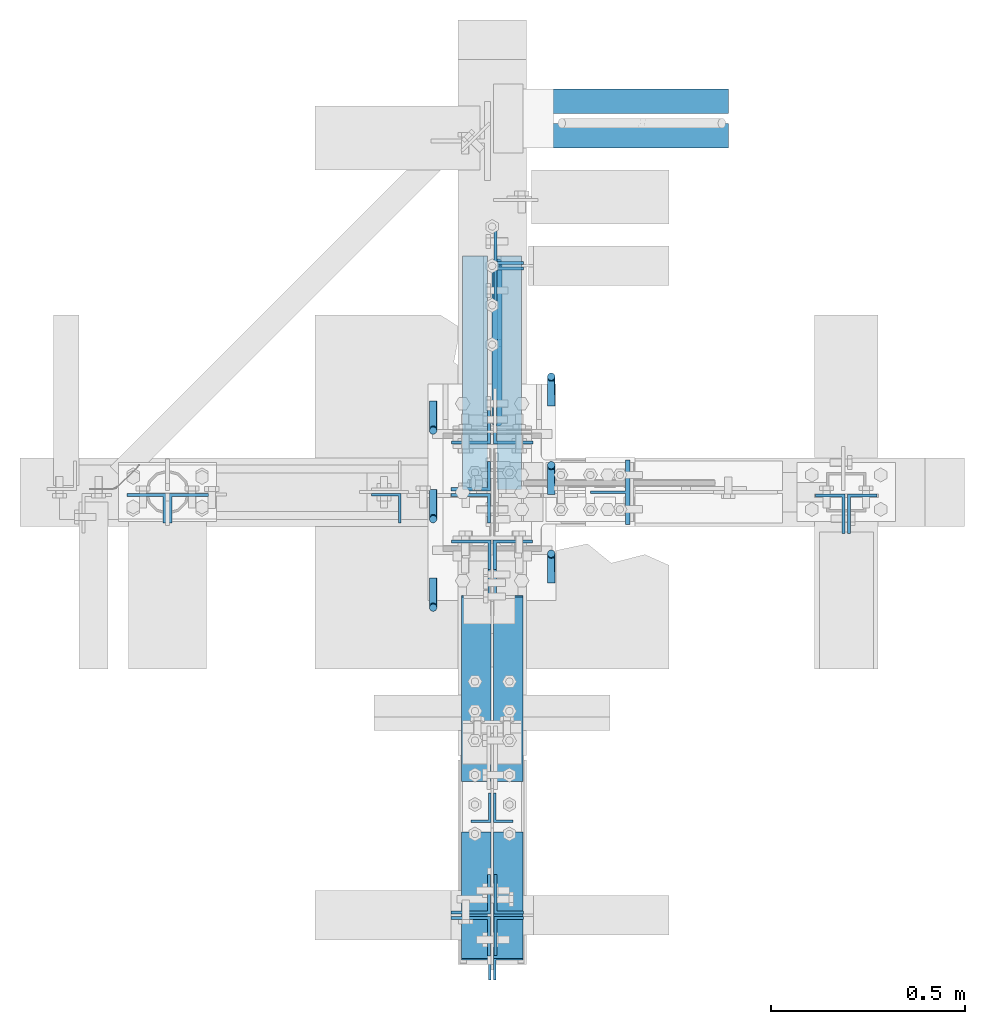
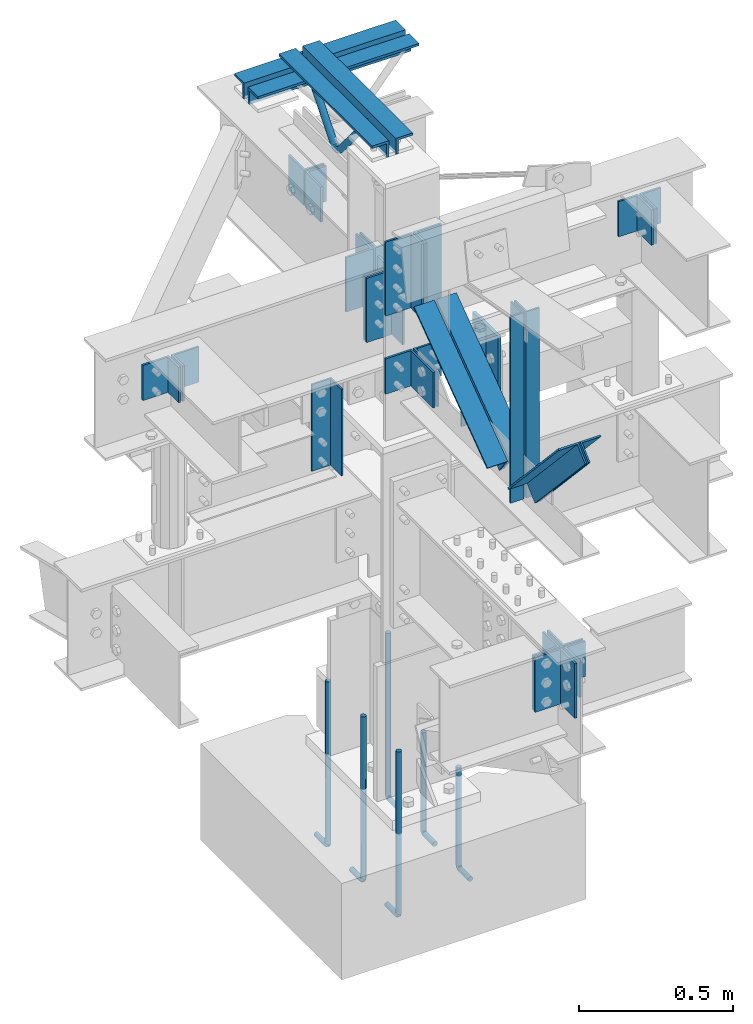
# Not in any storey, part 1 of 8: 29 members, 8 columns, 18 elements without a shape of their own.
"""IFC2X3 building model written with IfcOpenShell, lengths in inches."""

from ifc_helpers import new_model, entity, si_unit, converted_unit, frame, origin_with_axes, place, context, project, spatial, faceted_brep, source, transform, mapped, material, type_object, type_shapes, element, aggregate, save


model = new_model("IFC2X3")

# Units and contexts
model_context = context("Model", 3, precision=1e-05, world=origin_with_axes())
ifc_project = project(units=[converted_unit("LENGTHUNIT", "INCH", entity("IfcLengthMeasure", 25.4), si_unit("LENGTHUNIT", "METRE", prefix="MILLI"), dimensions=[1, 0, 0, 0, 0, 0, 0]), si_unit("PLANEANGLEUNIT", "RADIAN"), si_unit("MASSUNIT", "GRAM", prefix="KILO"), si_unit("TIMEUNIT", "SECOND"), si_unit("AREAUNIT", "SQUARE_METRE"), si_unit("PRESSUREUNIT", "PASCAL"), si_unit("FORCEUNIT", "NEWTON"), si_unit("THERMODYNAMICTEMPERATUREUNIT", "DEGREE_CELSIUS")], contexts=[model_context])

# Site, building
site_placement = place(None, origin_with_axes())
site = spatial("IfcSite", under=ifc_project, at=site_placement, CompositionType="ELEMENT")
building_placement = place(site_placement, origin_with_axes())
building = spatial("IfcBuilding", under=site, at=building_placement, Name="Building", CompositionType="ELEMENT")

# Assembly, column
assembly_1_placement = place(building_placement, frame((-9.25, 0.0, 50.0), z_axis=(-1.0, 0.0, 0.0), x_axis=(0.0, 0.0, 1.0)))
assembly_1 = element("IfcElementAssembly", 1, at=assembly_1_placement, inside=building, Name="4-5", PredefinedType="NOTDEFINED")
ifc_material_1 = material()
column_type_1 = type_object("IfcColumnType", Name="L3x3x1/4", PredefinedType="COLUMN", material=ifc_material_1)
shared_shape_1 = source(origin_with_axes(), model_context, "Body", "Brep", [
    faceted_brep([(0.0, 0.25, 0.25), (0.0, 3.0, 0.25), (0.0, 3.0, 0.0), (0.0, 0.0, 0.0), (0.0, 0.0, 3.0), (0.0, 0.25, 3.0), (13.5, 0.25, 3.0), (13.5, 0.0, 3.0), (13.5, 0.0, 0.0), (13.5, 3.0, 0.0), (13.5, 3.0, 0.25), (13.5, 0.25, 0.25)], [[[0, 1, 2, 3, 4, 5]], [[6, 7, 8, 9, 10, 11]], [[0, 11, 10, 1]], [[1, 10, 9, 2]], [[2, 9, 8, 3]], [[3, 8, 7, 4]], [[4, 7, 6, 5]], [[5, 6, 11, 0]]]),
])
type_shapes(column_type_1, [shared_shape_1])
column_1_placement = place(assembly_1_placement, frame((0.0, -0.15625, 0.0), z_axis=(0.0, -1.0, 0.0), x_axis=(1.0, 0.0, 0.0)))
column_1 = element("IfcColumn", 2, at=column_1_placement, type_object=column_type_1, Name="a36", ObjectType="Column", context=model_context, shape_type="MappedRepresentation", body=[
    mapped(shared_shape_1, transform((0.0, 0.0, 0.0), scale=1.0)),
])
aggregate(assembly_1, [column_1])

assembly_2_placement = place(building_placement, frame((14.0, 0.0, 49.0), z_axis=(0.0, -1.0, 0.0), x_axis=(0.0, 0.0, 1.0)))
assembly_2 = element("IfcElementAssembly", 3, at=assembly_2_placement, inside=building, Name="4-4", PredefinedType="NOTDEFINED")
ifc_material_2 = material()
column_type_2 = type_object("IfcColumnType", Name="WT4x14", PredefinedType="COLUMN", material=ifc_material_2)
shared_shape_2 = source(origin_with_axes(), model_context, "Body", "Brep", [
    faceted_brep([(0.0, -0.142, -4.03), (0.0, -0.142, -0.465), (0.0, -3.268, -0.465), (0.0, -3.268, 0.0), (0.0, 3.268, 0.0), (0.0, 3.268, -0.465), (0.0, 0.142, -0.465), (0.0, 0.142, -4.03), (14.625, 0.142, -4.03), (14.625, 0.142, -0.465), (14.625, 3.268, -0.465), (14.625, 3.268, 0.0), (14.625, -3.268, 0.0), (14.625, -3.268, -0.465), (14.625, -0.142, -0.465), (14.625, -0.142, -4.03)], [[[0, 1, 2, 3, 4, 5, 6, 7]], [[8, 9, 10, 11, 12, 13, 14, 15]], [[0, 15, 14, 1]], [[1, 14, 13, 2]], [[2, 13, 12, 3]], [[3, 12, 11, 4]], [[4, 11, 10, 5]], [[5, 10, 9, 6]], [[6, 9, 8, 7]], [[7, 8, 15, 0]]]),
])
type_shapes(column_type_2, [shared_shape_2])
column_2_placement = place(assembly_2_placement, frame((0.0, 0.0, 0.0), z_axis=(0.0, -1.0, 0.0), x_axis=(1.0, 0.0, 0.0)))
column_2 = element("IfcColumn", 4, at=column_2_placement, type_object=column_type_2, Name="wt6", ObjectType="Column", context=model_context, shape_type="MappedRepresentation", body=[
    mapped(shared_shape_2, transform((0.0, 0.0, 0.0), scale=1.0)),
])
aggregate(assembly_2, [column_2])

assembly_3_placement = place(building_placement, frame((3.0, 0.0, -22.6679382324219), z_axis=(0.0, -1.0, 0.0), x_axis=(0.0, 0.0, 1.0)))
assembly_3 = element("IfcElementAssembly", 5, at=assembly_3_placement, inside=building, Name="M_36", PredefinedType="NOTDEFINED")
column_3_placement = place(assembly_3_placement, frame((8.44018653035163, -3.0000000000418, 0.257887303829193), z_axis=(0.0, -1.0, 0.0), x_axis=(-1.0, 0.0, 0.0)))
cartesian_point_1 = entity("IfcCartesianPoint", [0.0, 0.0, 0.0])
ifc_direction_1 = entity("IfcDirection", [0.0, 0.0, 1.0])
ifc_direction_2 = entity("IfcDirection", [1.0, 0.0, 0.0])
column_3 = element("IfcColumn", 6, at=column_3_placement, Name="rb6", ObjectType="Member", context=model_context, shape_type="SweptSolid", body=[
    entity("IfcSurfaceCurveSweptAreaSolid", entity("IfcCircleProfileDef", "AREA", None, entity("IfcAxis2Placement2D", entity("IfcCartesianPoint", [0.0, 0.0]), entity("IfcDirection", [1.0, 0.0])), 0.375), entity("IfcAxis2Placement3D", cartesian_point_1, ifc_direction_1, ifc_direction_2), entity("IfcPolyline", [entity("IfcCartesianPoint", [0.2722, 0.0]), entity("IfcCartesianPoint", [0.2722, 2.5]), entity("IfcCartesianPoint", [0.234, 2.69304]), entity("IfcCartesianPoint", [0.0863, 2.88847]), entity("IfcCartesianPoint", [-0.164, 2.99645]), entity("IfcCartesianPoint", [-15.4778, 3.0])]), 0.0, 1.0, entity("IfcPlane", entity("IfcAxis2Placement3D", cartesian_point_1, ifc_direction_1, ifc_direction_2))),
])
aggregate(assembly_3, [column_3])

assembly_4_placement = place(building_placement, frame((3.0, -9.0, -22.6679382324219), z_axis=(0.0, -1.0, 0.0), x_axis=(0.0, 0.0, 1.0)))
assembly_4 = element("IfcElementAssembly", 7, at=assembly_4_placement, inside=building, Name="M_36", PredefinedType="NOTDEFINED")
column_4_placement = place(assembly_4_placement, frame((8.44018653035163, -3.0000000000418, 0.257887303829193), z_axis=(0.0, -1.0, 0.0), x_axis=(-1.0, 0.0, 0.0)))
cartesian_point_2 = entity("IfcCartesianPoint", [0.0, 0.0, 0.0])
ifc_direction_3 = entity("IfcDirection", [0.0, 0.0, 1.0])
ifc_direction_4 = entity("IfcDirection", [1.0, 0.0, 0.0])
column_4 = element("IfcColumn", 8, at=column_4_placement, Name="rb6", ObjectType="Member", context=model_context, shape_type="SweptSolid", body=[
    entity("IfcSurfaceCurveSweptAreaSolid", entity("IfcCircleProfileDef", "AREA", None, entity("IfcAxis2Placement2D", entity("IfcCartesianPoint", [0.0, 0.0]), entity("IfcDirection", [1.0, 0.0])), 0.375), entity("IfcAxis2Placement3D", cartesian_point_2, ifc_direction_3, ifc_direction_4), entity("IfcPolyline", [entity("IfcCartesianPoint", [0.2722, 0.0]), entity("IfcCartesianPoint", [0.2722, 2.5]), entity("IfcCartesianPoint", [0.234, 2.69304]), entity("IfcCartesianPoint", [0.0863, 2.88847]), entity("IfcCartesianPoint", [-0.164, 2.99645]), entity("IfcCartesianPoint", [-15.4778, 3.0])]), 0.0, 1.0, entity("IfcPlane", entity("IfcAxis2Placement3D", cartesian_point_2, ifc_direction_3, ifc_direction_4))),
])
aggregate(assembly_4, [column_4])

assembly_5_placement = place(building_placement, frame((3.0, 9.0, -22.6679382324219), z_axis=(0.0, -1.0, 0.0), x_axis=(0.0, 0.0, 1.0)))
assembly_5 = element("IfcElementAssembly", 9, at=assembly_5_placement, inside=building, Name="M_48", PredefinedType="NOTDEFINED")
column_5_placement = place(assembly_5_placement, frame((8.44018653035163, -3.0000000000418, 0.257887303829193), z_axis=(0.0, -1.0, 0.0), x_axis=(-1.0, 0.0, 0.0)))
cartesian_point_3 = entity("IfcCartesianPoint", [0.0, 0.0, 0.0])
ifc_direction_5 = entity("IfcDirection", [0.0, 0.0, 1.0])
ifc_direction_6 = entity("IfcDirection", [1.0, 0.0, 0.0])
column_5 = element("IfcColumn", 10, at=column_5_placement, Name="rb8", ObjectType="Member", context=model_context, shape_type="SweptSolid", body=[
    entity("IfcSurfaceCurveSweptAreaSolid", entity("IfcCircleProfileDef", "AREA", None, entity("IfcAxis2Placement2D", entity("IfcCartesianPoint", [0.0, 0.0]), entity("IfcDirection", [1.0, 0.0])), 0.375), entity("IfcAxis2Placement3D", cartesian_point_3, ifc_direction_5, ifc_direction_6), entity("IfcPolyline", [entity("IfcCartesianPoint", [0.2722, 0.0]), entity("IfcCartesianPoint", [0.2722, 2.5]), entity("IfcCartesianPoint", [0.234, 2.69304]), entity("IfcCartesianPoint", [0.0863, 2.88847]), entity("IfcCartesianPoint", [-0.164, 2.99645]), entity("IfcCartesianPoint", [-25.4778, 3.0])]), 0.0, 1.0, entity("IfcPlane", entity("IfcAxis2Placement3D", cartesian_point_3, ifc_direction_5, ifc_direction_6))),
])
aggregate(assembly_5, [column_5])

assembly_6_placement = place(building_placement, frame((-3.0, 0.0, -22.6679382324219), z_axis=(0.0, -1.0, 0.0), x_axis=(0.0, 0.0, 1.0)))
assembly_6 = element("IfcElementAssembly", 11, at=assembly_6_placement, inside=building, Name="M_35", PredefinedType="NOTDEFINED")
column_6_placement = place(assembly_6_placement, frame((8.44018653035163, 3.0000000000418, -0.257887303829193), z_axis=(0.0, 1.0, 0.0), x_axis=(-1.0, 0.0, 0.0)))
cartesian_point_4 = entity("IfcCartesianPoint", [0.0, 0.0, 0.0])
ifc_direction_7 = entity("IfcDirection", [0.0, 0.0, 1.0])
ifc_direction_8 = entity("IfcDirection", [1.0, 0.0, 0.0])
column_6 = element("IfcColumn", 12, at=column_6_placement, Name="rb6", ObjectType="Member", context=model_context, shape_type="SweptSolid", body=[
    entity("IfcSurfaceCurveSweptAreaSolid", entity("IfcCircleProfileDef", "AREA", None, entity("IfcAxis2Placement2D", entity("IfcCartesianPoint", [0.0, 0.0]), entity("IfcDirection", [1.0, 0.0])), 0.375), entity("IfcAxis2Placement3D", cartesian_point_4, ifc_direction_7, ifc_direction_8), entity("IfcPolyline", [entity("IfcCartesianPoint", [0.2722, 0.0]), entity("IfcCartesianPoint", [0.2722, 2.5]), entity("IfcCartesianPoint", [0.234, 2.69304]), entity("IfcCartesianPoint", [0.0863, 2.88847]), entity("IfcCartesianPoint", [-0.164, 2.99645]), entity("IfcCartesianPoint", [-25.4778, 3.0])]), 0.0, 1.0, entity("IfcPlane", entity("IfcAxis2Placement3D", cartesian_point_4, ifc_direction_7, ifc_direction_8))),
])
aggregate(assembly_6, [column_6])

assembly_7_placement = place(building_placement, frame((-3.0, -9.0, -22.6679382324219), z_axis=(0.0, -1.0, 0.0), x_axis=(0.0, 0.0, 1.0)))
assembly_7 = element("IfcElementAssembly", 13, at=assembly_7_placement, inside=building, Name="M_35", PredefinedType="NOTDEFINED")
column_7_placement = place(assembly_7_placement, frame((8.44018653035163, 3.0000000000418, -0.257887303829193), z_axis=(0.0, 1.0, 0.0), x_axis=(-1.0, 0.0, 0.0)))
cartesian_point_5 = entity("IfcCartesianPoint", [0.0, 0.0, 0.0])
ifc_direction_9 = entity("IfcDirection", [0.0, 0.0, 1.0])
ifc_direction_10 = entity("IfcDirection", [1.0, 0.0, 0.0])
column_7 = element("IfcColumn", 14, at=column_7_placement, Name="rb6", ObjectType="Member", context=model_context, shape_type="SweptSolid", body=[
    entity("IfcSurfaceCurveSweptAreaSolid", entity("IfcCircleProfileDef", "AREA", None, entity("IfcAxis2Placement2D", entity("IfcCartesianPoint", [0.0, 0.0]), entity("IfcDirection", [1.0, 0.0])), 0.375), entity("IfcAxis2Placement3D", cartesian_point_5, ifc_direction_9, ifc_direction_10), entity("IfcPolyline", [entity("IfcCartesianPoint", [0.2722, 0.0]), entity("IfcCartesianPoint", [0.2722, 2.5]), entity("IfcCartesianPoint", [0.234, 2.69304]), entity("IfcCartesianPoint", [0.0863, 2.88847]), entity("IfcCartesianPoint", [-0.164, 2.99645]), entity("IfcCartesianPoint", [-25.4778, 3.0])]), 0.0, 1.0, entity("IfcPlane", entity("IfcAxis2Placement3D", cartesian_point_5, ifc_direction_9, ifc_direction_10))),
])
aggregate(assembly_7, [column_7])

assembly_8_placement = place(building_placement, frame((-3.0, 9.0, -22.6679382324219), z_axis=(0.0, -1.0, 0.0), x_axis=(0.0, 0.0, 1.0)))
assembly_8 = element("IfcElementAssembly", 15, at=assembly_8_placement, inside=building, Name="M_50", PredefinedType="NOTDEFINED")
column_8_placement = place(assembly_8_placement, frame((8.44018653035163, 3.0000000000418, -0.257887303829193), z_axis=(0.0, 1.0, 0.0), x_axis=(-1.0, 0.0, 0.0)))
cartesian_point_6 = entity("IfcCartesianPoint", [0.0, 0.0, 0.0])
ifc_direction_11 = entity("IfcDirection", [0.0, 0.0, 1.0])
ifc_direction_12 = entity("IfcDirection", [1.0, 0.0, 0.0])
column_8 = element("IfcColumn", 16, at=column_8_placement, Name="rb8", ObjectType="Member", context=model_context, shape_type="SweptSolid", body=[
    entity("IfcSurfaceCurveSweptAreaSolid", entity("IfcCircleProfileDef", "AREA", None, entity("IfcAxis2Placement2D", entity("IfcCartesianPoint", [0.0, 0.0]), entity("IfcDirection", [1.0, 0.0])), 0.375), entity("IfcAxis2Placement3D", cartesian_point_6, ifc_direction_11, ifc_direction_12), entity("IfcPolyline", [entity("IfcCartesianPoint", [0.2722, 0.0]), entity("IfcCartesianPoint", [0.2722, 2.5]), entity("IfcCartesianPoint", [0.234, 2.69304]), entity("IfcCartesianPoint", [0.0863, 2.88847]), entity("IfcCartesianPoint", [-0.164, 2.99645]), entity("IfcCartesianPoint", [-25.4778, 3.0])]), 0.0, 1.0, entity("IfcPlane", entity("IfcAxis2Placement3D", cartesian_point_6, ifc_direction_11, ifc_direction_12))),
])
aggregate(assembly_8, [column_8])

# Assembly, member
assembly_9_placement = place(building_placement, frame((0.0, 0.0, 97.0), z_axis=(0.0, 0.0, -1.0), x_axis=(0.0, 1.0, 0.0)))
assembly_9 = element("IfcElementAssembly", 17, at=assembly_9_placement, inside=building, Name="M_40", PredefinedType="NOTDEFINED")
member_type_1 = type_object("IfcMemberType", Name="L2-1/2x2-1/2x3/8", PredefinedType="USERDEFINED", material=ifc_material_1)
shared_shape_3 = source(origin_with_axes(), model_context, "Body", "Brep", [
    faceted_brep([(0.0, 0.375, 0.375), (0.0, 2.5, 0.375), (0.0, 2.5, 0.0), (0.0, 0.0, 0.0), (0.0, 0.0, 2.5), (0.0, 0.375, 2.5), (23.75, 0.375, 2.5), (23.75, 0.0, 2.5), (23.75, 0.0, 0.0), (23.75, 2.5, 0.0), (23.75, 2.5, 0.375), (23.75, 0.375, 0.375)], [[[0, 1, 2, 3, 4, 5]], [[6, 7, 8, 9, 10, 11]], [[0, 11, 10, 1]], [[1, 10, 9, 2]], [[2, 9, 8, 3]], [[3, 8, 7, 4]], [[4, 7, 6, 5]], [[5, 6, 11, 0]]]),
])
type_shapes(member_type_1, [shared_shape_3])
member_1_placement = place(assembly_9_placement, frame((0.25, 0.5, 0.0), z_axis=(0.0, 0.0, 1.0), x_axis=(1.0, 0.0, 0.0)))
member_1 = element("IfcMember", 18, at=member_1_placement, type_object=member_type_1, Name="a32", ObjectType="Member", context=model_context, shape_type="MappedRepresentation", body=[
    mapped(shared_shape_3, transform((0.0, 0.0, 0.0), scale=1.0)),
])

assembly_10_placement = place(building_placement, frame((0.0, 38.0, 82.5), z_axis=(0.0, 0.0, -1.0), x_axis=(1.0, 0.0, 0.0)))
assembly_10 = element("IfcElementAssembly", 19, at=assembly_10_placement, inside=building, Name="M_41", PredefinedType="NOTDEFINED")
member_2_placement = place(assembly_10_placement, frame((0.25, 0.5, 0.0), z_axis=(0.0, 0.0, 1.0), x_axis=(1.0, 0.0, 0.0)))
member_2 = element("IfcMember", 20, at=member_2_placement, type_object=member_type_1, Name="a32", ObjectType="Member", context=model_context, shape_type="MappedRepresentation", body=[
    mapped(shared_shape_3, transform((0.0, 0.0, 0.0), scale=1.0)),
])

# Member
member_type_2 = type_object("IfcMemberType", Name="L2-1/2x2-1/2x3/8", PredefinedType="USERDEFINED", material=ifc_material_1)
shared_shape_4 = source(origin_with_axes(), model_context, "Body", "Brep", [
    faceted_brep([(0.0, 0.0, 0.0), (0.0, -2.5, 0.0), (0.0, -2.5, 0.375), (0.0, -0.375, 0.375), (0.0, -0.375, 2.5), (0.0, 0.0, 2.5), (23.75, 0.0, 2.5), (23.75, -0.375, 2.5), (23.75, -0.375, 0.375), (23.75, -2.5, 0.375), (23.75, -2.5, 0.0), (23.75, 0.0, 0.0)], [[[0, 1, 2, 3, 4, 5]], [[6, 7, 8, 9, 10, 11]], [[0, 11, 10, 1]], [[1, 10, 9, 2]], [[2, 9, 8, 3]], [[3, 8, 7, 4]], [[4, 7, 6, 5]], [[5, 6, 11, 0]]]),
])
type_shapes(member_type_2, [shared_shape_4])
member_3_placement = place(assembly_9_placement, frame((0.25, -0.5, 0.0), z_axis=(0.0, 0.0, 1.0), x_axis=(1.0, 0.0, 0.0)))
member_3 = element("IfcMember", 21, at=member_3_placement, type_object=member_type_2, Name="a6", ObjectType="Member", context=model_context, shape_type="MappedRepresentation", body=[
    mapped(shared_shape_4, transform((0.0, 0.0, 0.0), scale=1.0)),
])

member_4_placement = place(assembly_10_placement, frame((0.25, -0.5, 0.0), z_axis=(0.0, 0.0, 1.0), x_axis=(1.0, 0.0, 0.0)))
member_4 = element("IfcMember", 22, at=member_4_placement, type_object=member_type_2, Name="a6", ObjectType="Member", context=model_context, shape_type="MappedRepresentation", body=[
    mapped(shared_shape_4, transform((0.0, 0.0, 0.0), scale=1.0)),
])

aggregate(assembly_10, [member_4, member_2])

# Assembly, members
assembly_11_placement = place(building_placement, frame((0.0, -43.0, 46.0), z_axis=(0.0, 0.0, 1.0), x_axis=(1.0, 0.0, 0.0)))
assembly_11 = element("IfcElementAssembly", 23, at=assembly_11_placement, inside=building, Name="3-6", PredefinedType="NOTDEFINED")
member_type_3 = type_object("IfcMemberType", Name="L4x3x5/16", PredefinedType="USERDEFINED", material=ifc_material_1)
shared_shape_5 = source(origin_with_axes(), model_context, "Body", "Brep", [
    faceted_brep([(0.0, 0.0, 0.0), (0.0, -3.0, 0.0), (0.0, -3.0, 0.3125), (0.0, -0.3125, 0.3125), (0.0, -0.3125, 4.0), (0.0, 0.0, 4.0), (5.5, 0.0, 4.0), (5.5, -0.3125, 4.0), (5.5, -0.3125, 0.3125), (5.5, -3.0, 0.3125), (5.5, -3.0, 0.0), (5.5, 0.0, 0.0)], [[[0, 1, 2, 3, 4, 5]], [[6, 7, 8, 9, 10, 11]], [[0, 11, 10, 1]], [[1, 10, 9, 2]], [[2, 9, 8, 3]], [[3, 8, 7, 4]], [[4, 7, 6, 5]], [[5, 6, 11, 0]]]),
])
type_shapes(member_type_3, [shared_shape_5])
member_5_placement = place(assembly_11_placement, frame((0.1875, -0.117499999701977, -7.25), z_axis=(0.0, -1.0, 0.0), x_axis=(0.0, 0.0, 1.0)))
member_5 = element("IfcMember", 24, at=member_5_placement, type_object=member_type_3, Name="a12", ObjectType="Beam", context=model_context, shape_type="MappedRepresentation", body=[
    mapped(shared_shape_5, transform((0.0, 0.0, 0.0), scale=1.0)),
])
member_6_placement = place(assembly_11_placement, frame((0.1875, 0.117499999701977, -1.75), z_axis=(0.0, 1.0, 0.0), x_axis=(0.0, 0.0, -1.0)))
member_6 = element("IfcMember", 25, at=member_6_placement, type_object=member_type_3, Name="a12", ObjectType="Beam", context=model_context, shape_type="MappedRepresentation", body=[
    mapped(shared_shape_5, transform((0.0, 0.0, 0.0), scale=1.0)),
])
aggregate(assembly_11, [member_5, member_6])

assembly_12_placement = place(building_placement, frame((-33.0, 0.0, 77.0), z_axis=(0.0, 0.0, 1.0), x_axis=(0.0, -1.0, 0.0)))
assembly_12 = element("IfcElementAssembly", 26, at=assembly_12_placement, inside=building, Name="3-10", PredefinedType="NOTDEFINED")
member_7_placement = place(assembly_12_placement, frame((0.125, -0.144999995827675, -7.25), z_axis=(0.0, -1.0, 0.0), x_axis=(0.0, 0.0, 1.0)))
member_7 = element("IfcMember", 27, at=member_7_placement, type_object=member_type_3, Name="a31", ObjectType="Beam", context=model_context, shape_type="MappedRepresentation", body=[
    mapped(shared_shape_5, transform((0.0, 0.0, 0.0), scale=1.0)),
])
member_8_placement = place(assembly_12_placement, frame((0.125, 0.144999995827675, -1.75), z_axis=(0.0, 1.0, 0.0), x_axis=(0.0, 0.0, -1.0)))
member_8 = element("IfcMember", 28, at=member_8_placement, type_object=member_type_3, Name="a31", ObjectType="Beam", context=model_context, shape_type="MappedRepresentation", body=[
    mapped(shared_shape_5, transform((0.0, 0.0, 0.0), scale=1.0)),
])
aggregate(assembly_12, [member_7, member_8])

assembly_13_placement = place(building_placement, frame((0.0, 23.0, 82.5), z_axis=(0.0, 0.0, 1.0), x_axis=(1.0, 0.0, 0.0)))
assembly_13 = element("IfcElementAssembly", 29, at=assembly_13_placement, inside=building, Name="3-11", PredefinedType="NOTDEFINED")
member_9_placement = place(assembly_13_placement, frame((0.1875, -0.125, -9.75), z_axis=(0.0, -1.0, 0.0), x_axis=(0.0, 0.0, 1.0)))
member_9 = element("IfcMember", 30, at=member_9_placement, type_object=member_type_3, Name="a31", ObjectType="Beam", context=model_context, shape_type="MappedRepresentation", body=[
    mapped(shared_shape_5, transform((0.0, 0.0, 0.0), scale=1.0)),
])
member_10_placement = place(assembly_13_placement, frame((0.1875, 0.125, -4.25), z_axis=(0.0, 1.0, 0.0), x_axis=(0.0, 0.0, -1.0)))
member_10 = element("IfcMember", 31, at=member_10_placement, type_object=member_type_3, Name="a31", ObjectType="Beam", context=model_context, shape_type="MappedRepresentation", body=[
    mapped(shared_shape_5, transform((0.0, 0.0, 0.0), scale=1.0)),
])
aggregate(assembly_13, [member_9, member_10])

assembly_14_placement = place(building_placement, frame((0.0, -43.0, 46.0), z_axis=(0.0, 0.0, 1.0), x_axis=(-1.0, 0.0, 0.0)))
assembly_14 = element("IfcElementAssembly", 32, at=assembly_14_placement, inside=building, Name="3-5", PredefinedType="NOTDEFINED")
member_type_4 = type_object("IfcMemberType", Name="L4x4x5/16", PredefinedType="USERDEFINED", material=ifc_material_1)
shared_shape_6 = source(origin_with_axes(), model_context, "Body", "Brep", [
    faceted_brep([(0.0, 0.0, 0.0), (0.0, -4.0, 0.0), (0.0, -4.0, 0.3125), (0.0, -0.3125, 0.3125), (0.0, -0.3125, 4.0), (0.0, 0.0, 4.0), (8.5, 0.0, 4.0), (8.5, -0.3125, 4.0), (8.5, -0.3125, 0.3125), (8.5, -4.0, 0.3125), (8.5, -4.0, 0.0), (8.5, 0.0, 0.0)], [[[0, 1, 2, 3, 4, 5]], [[6, 7, 8, 9, 10, 11]], [[0, 11, 10, 1]], [[1, 10, 9, 2]], [[2, 9, 8, 3]], [[3, 8, 7, 4]], [[4, 7, 6, 5]], [[5, 6, 11, 0]]]),
])
type_shapes(member_type_4, [shared_shape_6])
member_11_placement = place(assembly_14_placement, frame((0.1875, -0.127499997615814, -10.25), z_axis=(0.0, -1.0, 0.0), x_axis=(0.0, 0.0, 1.0)))
member_11 = element("IfcMember", 33, at=member_11_placement, type_object=member_type_4, Name="a9", ObjectType="Beam", context=model_context, shape_type="MappedRepresentation", body=[
    mapped(shared_shape_6, transform((0.0, 0.0, 0.0), scale=1.0)),
])
member_12_placement = place(assembly_14_placement, frame((0.1875, 0.127499997615814, -1.75), z_axis=(0.0, 1.0, 0.0), x_axis=(0.0, 0.0, -1.0)))
member_12 = element("IfcMember", 34, at=member_12_placement, type_object=member_type_4, Name="a9", ObjectType="Beam", context=model_context, shape_type="MappedRepresentation", body=[
    mapped(shared_shape_6, transform((0.0, 0.0, 0.0), scale=1.0)),
])
aggregate(assembly_14, [member_11, member_12])

assembly_15_placement = place(building_placement, frame((0.0, 0.0, 80.0), z_axis=(0.0, 0.0, 1.0), x_axis=(0.0, 1.0, 0.0)))
assembly_15 = element("IfcElementAssembly", 35, at=assembly_15_placement, inside=building, Name="2-6", PredefinedType="NOTDEFINED")
member_13_placement = place(assembly_15_placement, frame((4.875, -0.14750000834465, -11.25), z_axis=(0.0, -1.0, 0.0), x_axis=(0.0, 0.0, 1.0)))
member_13 = element("IfcMember", 36, at=member_13_placement, type_object=member_type_4, Name="a7", ObjectType="Beam", context=model_context, shape_type="MappedRepresentation", body=[
    mapped(shared_shape_6, transform((0.0, 0.0, 0.0), scale=1.0)),
])
member_14_placement = place(assembly_15_placement, frame((4.875, 0.14750000834465, -2.75), z_axis=(0.0, 1.0, 0.0), x_axis=(0.0, 0.0, -1.0)))
member_14 = element("IfcMember", 37, at=member_14_placement, type_object=member_type_4, Name="a7", ObjectType="Beam", context=model_context, shape_type="MappedRepresentation", body=[
    mapped(shared_shape_6, transform((0.0, 0.0, 0.0), scale=1.0)),
])
aggregate(assembly_15, [member_13, member_14])

assembly_16_placement = place(building_placement, frame((0.0, 0.0, 80.0), z_axis=(0.0, 0.0, 1.0), x_axis=(-1.0, 0.0, 0.0)))
assembly_16 = element("IfcElementAssembly", 38, at=assembly_16_placement, inside=building, Name="2-7", PredefinedType="NOTDEFINED")
member_type_5 = type_object("IfcMemberType", Name="L4x3x5/16", PredefinedType="USERDEFINED", material=ifc_material_1)
shared_shape_7 = source(origin_with_axes(), model_context, "Body", "Brep", [
    faceted_brep([(0.0, 0.3125, 0.3125), (0.0, 3.0, 0.3125), (0.0, 3.0, 0.0), (0.0, 0.0, 0.0), (0.0, 0.0, 4.0), (0.0, 0.3125, 4.0), (10.0, 0.3125, 4.0), (10.0, 0.0, 4.0), (10.0, 0.0, 0.0), (10.0, 3.0, 0.0), (10.0, 3.0, 0.3125), (10.0, 0.3125, 0.3125)], [[[0, 1, 2, 3, 4, 5]], [[6, 7, 8, 9, 10, 11]], [[0, 11, 10, 1]], [[1, 10, 9, 2]], [[2, 9, 8, 3]], [[3, 8, 7, 4]], [[4, 7, 6, 5]], [[5, 6, 11, 0]]]),
])
type_shapes(member_type_5, [shared_shape_7])
member_15_placement = place(assembly_16_placement, frame((0.1875, -0.137500002980232, -12.75), z_axis=(1.0, 0.0, 0.0), x_axis=(0.0, 0.0, 1.0)))
member_15 = element("IfcMember", 39, at=member_15_placement, type_object=member_type_5, Name="a8", ObjectType="Beam", context=model_context, shape_type="MappedRepresentation", body=[
    mapped(shared_shape_7, transform((0.0, 0.0, 0.0), scale=1.0)),
])
member_16_placement = place(assembly_16_placement, frame((0.1875, 0.137500002980232, -2.75), z_axis=(1.0, 0.0, 0.0), x_axis=(0.0, 0.0, -1.0)))
member_16 = element("IfcMember", 40, at=member_16_placement, type_object=member_type_5, Name="a10", ObjectType="Beam", context=model_context, shape_type="MappedRepresentation", body=[
    mapped(shared_shape_7, transform((0.0, 0.0, 0.0), scale=1.0)),
])
aggregate(assembly_16, [member_15, member_16])

assembly_17_placement = place(building_placement, frame((36.0, 0.0, 78.0), z_axis=(0.0, 0.0, 1.0), x_axis=(0.0, -1.0, 0.0)))
assembly_17 = element("IfcElementAssembly", 41, at=assembly_17_placement, inside=building, Name="3-9", PredefinedType="NOTDEFINED")
member_type_6 = type_object("IfcMemberType", Name="L4x3x5/16", PredefinedType="USERDEFINED", material=ifc_material_1)
shared_shape_8 = source(origin_with_axes(), model_context, "Body", "Brep", [
    faceted_brep([(0.0, 0.3125, 0.3125), (0.0, 3.0, 0.3125), (0.0, 3.0, 0.0), (0.0, 0.0, 0.0), (0.0, 0.0, 4.0), (0.0, 0.3125, 4.0), (5.5, 0.3125, 4.0), (5.5, 0.0, 4.0), (5.5, 0.0, 0.0), (5.5, 3.0, 0.0), (5.5, 3.0, 0.3125), (5.5, 0.3125, 0.3125)], [[[0, 1, 2, 3, 4, 5]], [[6, 7, 8, 9, 10, 11]], [[0, 11, 10, 1]], [[1, 10, 9, 2]], [[2, 9, 8, 3]], [[3, 8, 7, 4]], [[4, 7, 6, 5]], [[5, 6, 11, 0]]]),
])
type_shapes(member_type_6, [shared_shape_8])
member_17_placement = place(assembly_17_placement, frame((0.1875, -0.115000002086163, -7.25), z_axis=(1.0, 0.0, 0.0), x_axis=(0.0, 0.0, 1.0)))
member_17 = element("IfcMember", 42, at=member_17_placement, type_object=member_type_6, Name="a5", ObjectType="Beam", context=model_context, shape_type="MappedRepresentation", body=[
    mapped(shared_shape_8, transform((0.0, 0.0, 0.0), scale=1.0)),
])
member_18_placement = place(assembly_17_placement, frame((0.1875, 0.115000002086163, -1.75), z_axis=(1.0, 0.0, 0.0), x_axis=(0.0, 0.0, -1.0)))
member_18 = element("IfcMember", 43, at=member_18_placement, type_object=member_type_6, Name="a5", ObjectType="Beam", context=model_context, shape_type="MappedRepresentation", body=[
    mapped(shared_shape_8, transform((0.0, 0.0, 0.0), scale=1.0)),
])
aggregate(assembly_17, [member_17, member_18])

assembly_18_placement = place(building_placement, frame((0.0, -47.9999999999999, 94.0), z_axis=(0.0, 0.17437043319647, 0.984680126755321), x_axis=(0.0, 0.98468012675532, -0.17437043319647)))
assembly_18 = element("IfcElementAssembly", 44, at=assembly_18_placement, inside=building, Name="4-8", PredefinedType="NOTDEFINED")
member_type_7 = type_object("IfcMemberType", Name="L4x3x5/16", PredefinedType="USERDEFINED", material=ifc_material_1)
shared_shape_9 = source(origin_with_axes(), model_context, "Body", "Brep", [
    faceted_brep([(0.0, 0.3125, 0.3125), (0.0, 3.0, 0.3125), (0.0, 3.0, 0.0), (0.0, 0.0, 0.0), (0.0, 0.0, 4.0), (0.0, 0.3125, 4.0), (11.5, 0.3125, 4.0), (11.5, 0.0, 4.0), (11.5, 0.0, 0.0), (11.5, 3.0, 0.0), (11.5, 3.0, 0.3125), (11.5, 0.3125, 0.3125)], [[[0, 1, 2, 3, 4, 5]], [[6, 7, 8, 9, 10, 11]], [[0, 11, 10, 1]], [[1, 10, 9, 2]], [[2, 9, 8, 3]], [[3, 8, 7, 4]], [[4, 7, 6, 5]], [[5, 6, 11, 0]]]),
])
type_shapes(member_type_7, [shared_shape_9])
member_19_placement = place(assembly_18_placement, frame((45.9081465219534, -0.107503354549408, -11.9277075718198), z_axis=(0.0, -1.0, 0.0), x_axis=(-0.17437043319647, 0.0, 0.984680126755321)))
member_19 = element("IfcMember", 45, at=member_19_placement, type_object=member_type_7, Name="a16", ObjectType="Beam", context=model_context, shape_type="MappedRepresentation", body=[
    mapped(shared_shape_9, transform((0.0, 0.0, 0.0), scale=1.0)),
])
member_20_placement = place(assembly_18_placement, frame((43.9028865401939, 0.122502744197844, -0.603886114133672), z_axis=(0.0, 1.0, 0.0), x_axis=(0.17437043319647, 0.0, -0.984680126755321)))
member_20 = element("IfcMember", 46, at=member_20_placement, type_object=member_type_7, Name="a16", ObjectType="Beam", context=model_context, shape_type="MappedRepresentation", body=[
    mapped(shared_shape_9, transform((0.0, 0.0, 0.0), scale=1.0)),
])
member_type_8 = type_object("IfcMemberType", Name="L6x4x5/16", PredefinedType="USERDEFINED", material=ifc_material_1)
shared_shape_10 = source(origin_with_axes(), model_context, "Body", "Brep", [
    faceted_brep([(0.0, 0.3125, 0.3125), (0.0, 4.0, 0.3125), (0.0, 4.0, 0.0), (0.0, 0.0, 0.0), (0.0, 0.0, 6.0), (0.0, 0.3125, 6.0), (5.5, 0.3125, 6.0), (5.5, 0.0, 6.0), (5.5, 0.0, 0.0), (5.5, 4.0, 0.0), (5.5, 4.0, 0.3125), (5.5, 0.3125, 0.3125)], [[[0, 1, 2, 3, 4, 5]], [[6, 7, 8, 9, 10, 11]], [[0, 11, 10, 1]], [[1, 10, 9, 2]], [[2, 9, 8, 3]], [[3, 8, 7, 4]], [[4, 7, 6, 5]], [[5, 6, 11, 0]]]),
])
type_shapes(member_type_8, [shared_shape_10])
member_21_placement = place(assembly_18_placement, frame((48.0431350813066, 0.115000002086163, -23.9267525398229), z_axis=(-0.98468012675532, 0.0, -0.17437043319647), x_axis=(-0.17437043319647, 0.0, 0.984680126755321)))
member_21 = element("IfcMember", 47, at=member_21_placement, type_object=member_type_8, Name="a26", ObjectType="Beam", context=model_context, shape_type="MappedRepresentation", body=[
    mapped(shared_shape_10, transform((0.0, 0.0, 0.0), scale=1.0)),
])
member_22_placement = place(assembly_18_placement, frame((47.084097698726, -0.115000002086165, -18.5110118426687), z_axis=(-0.98468012675532, 0.0, -0.17437043319647), x_axis=(0.17437043319647, 0.0, -0.984680126755321)))
member_22 = element("IfcMember", 48, at=member_22_placement, type_object=member_type_8, Name="a26", ObjectType="Beam", context=model_context, shape_type="MappedRepresentation", body=[
    mapped(shared_shape_10, transform((0.0, 0.0, 0.0), scale=1.0)),
])
member_type_9 = type_object("IfcMemberType", Name="L3x3x1/4", PredefinedType="USERDEFINED", material=ifc_material_1)
shared_shape_11 = source(origin_with_axes(), model_context, "Body", "Brep", [
    faceted_brep([(0.0, 0.0, 0.0), (0.0, -3.0, 0.0), (0.0, -3.0, 0.25), (0.0, -0.25, 0.25), (0.0, -0.25, 3.0), (0.0, 0.0, 3.0), (23.25, 0.0, 3.0), (23.25, -0.25, 3.0), (23.25, -0.25, 0.25), (23.25, -3.0, 0.25), (23.25, -3.0, 0.0), (23.25, 0.0, 0.0)], [[[0, 1, 2, 3, 4, 5]], [[6, 7, 8, 9, 10, 11]], [[0, 11, 10, 1]], [[1, 10, 9, 2]], [[2, 9, 8, 3]], [[3, 8, 7, 4]], [[4, 7, 6, 5]], [[5, 6, 11, 0]]]),
])
type_shapes(member_type_9, [shared_shape_11])
member_23_placement = place(assembly_18_placement, frame((23.3610050291526, -0.125, -25.3745518841465), z_axis=(0.0, -1.0, 0.0), x_axis=(0.691079008354412, 0.0, 0.72277922231611)))
member_23 = element("IfcMember", 49, at=member_23_placement, type_object=member_type_9, Name="a4", ObjectType="Beam", context=model_context, shape_type="MappedRepresentation", body=[
    mapped(shared_shape_11, transform((0.0, 0.0, 0.0), scale=1.0)),
])
member_24_placement = place(assembly_18_placement, frame((39.4285880667948, 0.125, -8.56993931105693), z_axis=(0.0, 1.0, 0.0), x_axis=(-0.691079008354409, 0.0, -0.722779222316112)))
member_24 = element("IfcMember", 50, at=member_24_placement, type_object=member_type_9, Name="a4", ObjectType="Beam", context=model_context, shape_type="MappedRepresentation", body=[
    mapped(shared_shape_11, transform((0.0, 0.0, 0.0), scale=1.0)),
])
member_type_10 = type_object("IfcMemberType", Name="L3x2x1/4", PredefinedType="USERDEFINED", material=ifc_material_1)
shared_shape_12 = source(origin_with_axes(), model_context, "Body", "Brep", [
    faceted_brep([(0.0, 0.25, 0.25), (0.0, 2.0, 0.25), (0.0, 2.0, 0.0), (0.0, 0.0, 0.0), (0.0, 0.0, 3.0), (0.0, 0.25, 3.0), (29.0, 0.25, 3.0), (29.0, 0.0, 3.0), (29.0, 0.0, 0.0), (29.0, 2.0, 0.0), (29.0, 2.0, 0.25), (29.0, 0.25, 0.25)], [[[0, 1, 2, 3, 4, 5]], [[6, 7, 8, 9, 10, 11]], [[0, 11, 10, 1]], [[1, 10, 9, 2]], [[2, 9, 8, 3]], [[3, 8, 7, 4]], [[4, 7, 6, 5]], [[5, 6, 11, 0]]]),
])
type_shapes(member_type_10, [shared_shape_12])
member_25_placement = place(assembly_18_placement, frame((19.8574554988699, -0.134998321533203, -29.3839910943416), z_axis=(0.98468012675532, 0.0, 0.17437043319647), x_axis=(-0.17437043319647, 0.0, 0.984680126755321)))
member_25 = element("IfcMember", 51, at=member_25_placement, type_object=member_type_10, Name="a21", ObjectType="Beam", context=model_context, shape_type="MappedRepresentation", body=[
    mapped(shared_shape_12, transform((0.0, 0.0, 0.0), scale=1.0)),
])
member_26_placement = place(assembly_18_placement, frame((14.8007129361722, 0.134998321533203, -0.828267418437292), z_axis=(0.98468012675532, 0.0, 0.17437043319647), x_axis=(0.17437043319647, 0.0, -0.984680126755321)))
member_26 = element("IfcMember", 52, at=member_26_placement, type_object=member_type_10, Name="a21", ObjectType="Beam", context=model_context, shape_type="MappedRepresentation", body=[
    mapped(shared_shape_12, transform((0.0, 0.0, 0.0), scale=1.0)),
])
member_type_11 = type_object("IfcMemberType", Name="L3x3x1/4", PredefinedType="USERDEFINED", material=ifc_material_1)
shared_shape_13 = source(origin_with_axes(), model_context, "Body", "Brep", [
    faceted_brep([(0.0, 0.0, 0.0), (0.0, -3.0, 0.0), (0.0, -3.0, 0.25), (0.0, -0.25, 0.25), (0.0, -0.25, 3.0), (0.0, 0.0, 3.0), (18.875, 0.0, 3.0), (18.875, -0.25, 3.0), (18.875, -0.25, 0.25), (18.875, -3.0, 0.25), (18.875, -3.0, 0.0), (18.875, 0.0, 0.0)], [[[0, 1, 2, 3, 4, 5]], [[6, 7, 8, 9, 10, 11]], [[0, 11, 10, 1]], [[1, 10, 9, 2]], [[2, 9, 8, 3]], [[3, 8, 7, 4]], [[4, 7, 6, 5]], [[5, 6, 11, 0]]]),
])
type_shapes(member_type_11, [shared_shape_13])
member_27_placement = place(assembly_18_placement, frame((3.24754149855325, -0.125, -14.8378072761302), z_axis=(0.0, -1.0, 0.0), x_axis=(0.79698579420595, 0.0, -0.603998049528234)))
member_27 = element("IfcMember", 53, at=member_27_placement, type_object=member_type_11, Name="a30", ObjectType="Beam", context=model_context, shape_type="MappedRepresentation", body=[
    mapped(shared_shape_13, transform((0.0, 0.0, 0.0), scale=1.0)),
])
member_28_placement = place(assembly_18_placement, frame((18.2906509515737, 0.125, -26.2382717407428), z_axis=(0.0, 1.0, 0.0), x_axis=(-0.796985794205948, 0.0, 0.603998049528234)))
member_28 = element("IfcMember", 54, at=member_28_placement, type_object=member_type_11, Name="a30", ObjectType="Beam", context=model_context, shape_type="MappedRepresentation", body=[
    mapped(shared_shape_13, transform((0.0, 0.0, 0.0), scale=1.0)),
])
aggregate(assembly_18, [member_19, member_21, member_20, member_23, member_24, member_25, member_26, member_27, member_28, member_22])

# Member
member_29_placement = place(assembly_9_placement, frame((23.4185070188086, 0.497068971505183, 1.55131149292049), z_axis=(0.0, 1.0, 0.0), x_axis=(0.642285189490803, 0.0, 0.766465743109738)))
cartesian_point_7 = entity("IfcCartesianPoint", [0.0, 0.0, 0.0])
ifc_direction_13 = entity("IfcDirection", [0.0, 0.0, 1.0])
member_29 = element("IfcMember", 55, at=member_29_placement, Name="rb2", ObjectType="Member", context=model_context, shape_type="SweptSolid", body=[
    entity("IfcSurfaceCurveSweptAreaSolid", entity("IfcCircleProfileDef", "AREA", None, entity("IfcAxis2Placement2D", entity("IfcCartesianPoint", [0.0, 0.0]), entity("IfcDirection", [1.0, 0.0])), 0.5), entity("IfcAxis2Placement3D", cartesian_point_7, ifc_direction_13, entity("IfcDirection", [1.0, 0.0, 0.0])), entity("IfcPolyline", [entity("IfcCartesianPoint", [-0.0454, -0.05412]), entity("IfcCartesianPoint", [1.9215, -11.20844]), entity("IfcCartesianPoint", [1.9183, -11.61735]), entity("IfcCartesianPoint", [1.7879, -11.96562]), entity("IfcCartesianPoint", [1.5227, -12.27681]), entity("IfcCartesianPoint", [1.199, -12.45983]), entity("IfcCartesianPoint", [0.7957, -12.52769]), entity("IfcCartesianPoint", [-10.4979, -12.52762])]), 0.0, 1.0, entity("IfcPlane", entity("IfcAxis2Placement3D", cartesian_point_7, entity("IfcDirection", [0.0, 1.0, 0.0]), ifc_direction_13))),
])

aggregate(assembly_9, [member_29, member_1, member_3])

save(model, "model.ifc")
